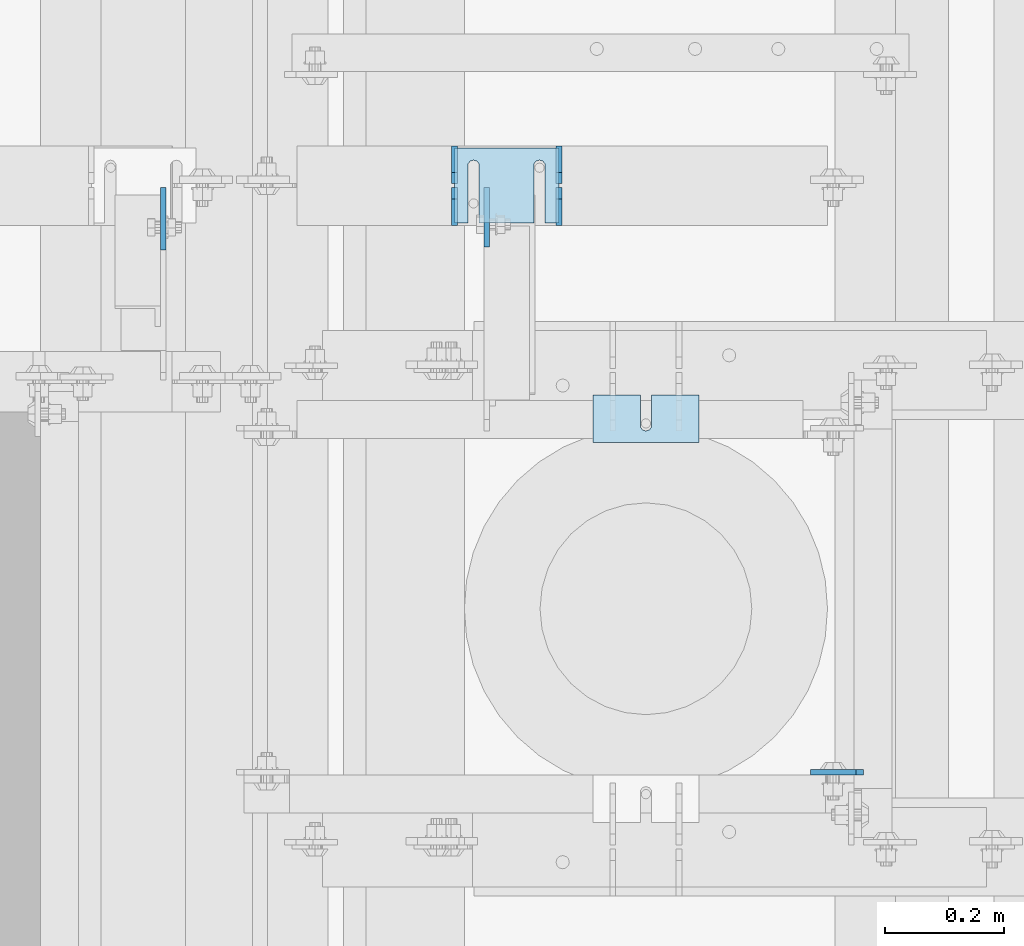
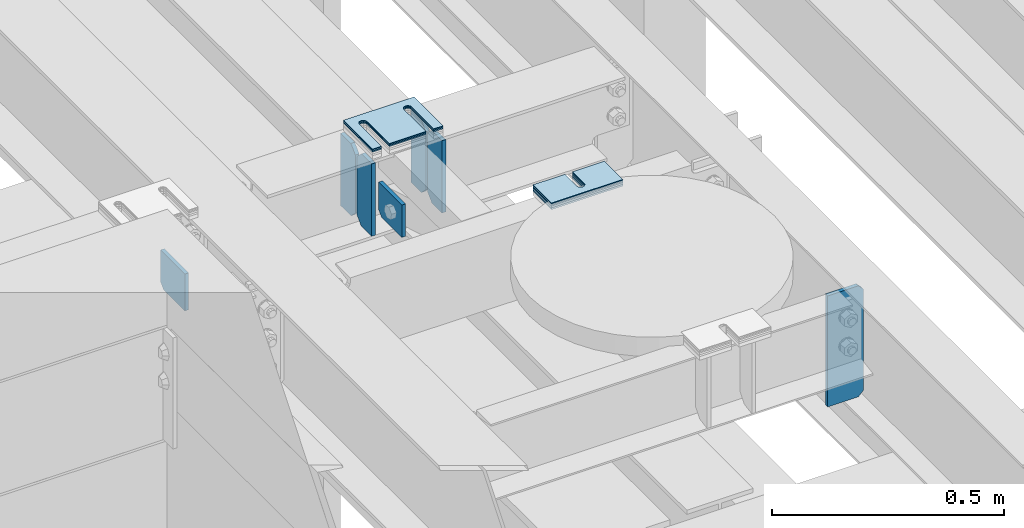
# One storey, part 1610 of 1876: 15 plates, 11 elements without a shape of their own.
"""IFC2X3 building model written with IfcOpenShell, lengths in millimetres."""

import ifcopenshell
import ifcopenshell.guid

model = None  # the IFC model being written
_history = None  # IfcOwnerHistory: only IFC2X3 demands one
_inside = {}  # id of a spatial element -> (the spatial element, [elements in it])
_under = {}  # id of a project, library or spatial element -> (it, [spatial elements below it])
_declared = {}  # id of a project -> (the project, [libraries it declares])
_typed = {}  # id of a type object -> (the type object, [elements of that type])
_made_of = {}  # id of a material, layer set ... -> (it, [elements and type objects made of it])


def new_model(schema):
    """Start an empty IFC model of exactly this schema.

    Asked for "IFC4X3", IfcOpenShell would pick the latest addendum, in which some entities
    have other attributes; the version numbers below select the first issue.
    IFC2X3 requires an IfcOwnerHistory on every rooted entity: one is made here for all.
    """
    global model, _history
    if schema == "IFC4X3":
        model = ifcopenshell.file(schema_version=(4, 3, 0, 0))
    else:
        model = ifcopenshell.file(schema=schema)
    _inside.clear()
    _under.clear()
    _declared.clear()
    _typed.clear()
    _made_of.clear()
    _history = None
    if model.schema == "IFC2X3":
        org = make("IfcOrganization", Name="unknown")
        user = make(
            "IfcPersonAndOrganization",
            ThePerson=make("IfcPerson", FamilyName="unknown"),
            TheOrganization=org,
        )
        app = make(
            "IfcApplication",
            ApplicationDeveloper=org,
            Version="unknown",
            ApplicationFullName="unknown",
            ApplicationIdentifier="unknown",
        )
        _history = make(
            "IfcOwnerHistory",
            OwningUser=user,
            OwningApplication=app,
            ChangeAction="ADDED",
            CreationDate=0,
        )
    return model


def make(cls, **values):
    """One entity of the class cls with the attributes given. An attribute that is None is left unset."""
    return model.create_entity(
        cls, **{name: value for name, value in values.items() if value is not None}
    )


def rooted(cls, **values):
    """An entity with a GlobalId (a new one), such as an element, a storey or a relation."""
    return make(cls, GlobalId=ifcopenshell.guid.new(), OwnerHistory=_history, **values)


def si_unit(unit_type, name, prefix=None):
    """IfcSIUnit, for example si_unit("LENGTHUNIT", "METRE", prefix="MILLI")."""
    return make("IfcSIUnit", UnitType=unit_type, Prefix=prefix, Name=name)


def assignment(units):
    """IfcUnitAssignment: the units of a project."""
    return None if units is None else make("IfcUnitAssignment", Units=units)


def point(xyz):
    """IfcCartesianPoint."""
    return None if xyz is None else make("IfcCartesianPoint", Coordinates=xyz)


def direction(xyz):
    """IfcDirection."""
    return None if xyz is None else make("IfcDirection", DirectionRatios=xyz)


def frame(location, z_axis=None, x_axis=None):
    """IfcAxis2Placement3D, a coordinate frame: its origin and axes. An axis left out is left unset."""
    return make(
        "IfcAxis2Placement3D",
        Location=point(location),
        Axis=direction(z_axis),
        RefDirection=direction(x_axis),
    )


def origin_with_axes():
    """The frame at (0, 0, 0) with the z axis (0, 0, 1) and the x axis (1, 0, 0) written out."""
    return frame((0.0, 0.0, 0.0), z_axis=(0.0, 0.0, 1.0), x_axis=(1.0, 0.0, 0.0))


def place(relative_to, where):
    """IfcLocalPlacement: puts the frame where relative to a parent placement (None: the world)."""
    return make(
        "IfcLocalPlacement", PlacementRelTo=relative_to, RelativePlacement=where
    )


def context(
    kind, dimensions, precision=None, world=None, true_north=None, identifier=None
):
    """IfcGeometricRepresentationContext, for example the 3D "Model" context."""
    return make(
        "IfcGeometricRepresentationContext",
        ContextIdentifier=identifier,
        ContextType=kind,
        CoordinateSpaceDimension=dimensions,
        Precision=precision,
        WorldCoordinateSystem=world,
        TrueNorth=true_north,
    )


def subcontext(parent, identifier, kind, view, scale=None):
    """IfcGeometricRepresentationSubContext, for example "Body" below "Model"."""
    return make(
        "IfcGeometricRepresentationSubContext",
        ContextIdentifier=identifier,
        ContextType=kind,
        ParentContext=parent,
        TargetScale=scale,
        TargetView=view,
    )


def project(units=None, contexts=None):
    """IfcProject with its units and contexts."""
    return rooted(
        "IfcProject",
        Name="project",
        RepresentationContexts=contexts,
        UnitsInContext=assignment(units),
    )


def spatial(cls, under=None, at=None, **own):
    """A site, building, storey or space (cls), placed at a placement, below another one or the project."""
    s = rooted(cls, ObjectPlacement=at, **own)
    if under is not None:
        _under.setdefault(under.id(), (under, []))[1].append(s)
    return s


def faces_of(points, faces, orient=None, outer=None):
    """IfcFace entities. A face is a list of loops; a loop is a list of indices into points, from 0.

    orient and outer hold one flag for each loop. By default every Orientation is true, the
    first loop of a face is its IfcFaceOuterBound and the others are IfcFaceBound.
    """
    made = []
    for i, loops in enumerate(faces):
        bounds = []
        for j, loop in enumerate(loops):
            is_outer = j == 0 if outer is None else outer[i][j]
            bounds.append(
                make(
                    "IfcFaceOuterBound" if is_outer else "IfcFaceBound",
                    Bound=make("IfcPolyLoop", Polygon=[points[k] for k in loop]),
                    Orientation=True if orient is None else orient[i][j],
                )
            )
        made.append(make("IfcFace", Bounds=bounds))
    return made


def faceted_brep(points, faces, orient=None, outer=None, voids=None):
    """IfcFacetedBrep: a solid bounded by flat faces; with voids (closed shells), ...WithVoids."""
    shared = [point(p) for p in points]
    hull = make("IfcClosedShell", CfsFaces=faces_of(shared, faces, orient, outer))
    if voids is None:
        return make("IfcFacetedBrep", Outer=hull)
    return make(
        "IfcFacetedBrepWithVoids",
        Outer=hull,
        Voids=[
            make(cls, CfsFaces=faces_of(shared, fs, o, b)) for cls, fs, o, b in voids
        ],
    )


def shape(context_of_items, identifier, shape_type, items):
    """IfcShapeRepresentation: the items that make up one representation, for example the "Body"."""
    return make(
        "IfcShapeRepresentation",
        ContextOfItems=context_of_items,
        RepresentationIdentifier=identifier,
        RepresentationType=shape_type,
        Items=items,
    )


def material(Name=None, Category=None):
    """IfcMaterial."""
    return make("IfcMaterial", Name=Name, Category=Category)


def made_of(thing, what):
    """Note that an element or type object is made of a material, layer set ...; save() writes the relation."""
    if what is not None:
        _made_of.setdefault(what.id(), (what, []))[1].append(thing)
    return thing


def type_object(cls, material=None, **own):
    """A type object (cls), such as IfcWallType, which elements share."""
    return made_of(rooted(cls, **own), material)


def element(
    cls,
    number,
    at=None,
    inside=None,
    cuts=None,
    type_object=None,
    material=None,
    context=None,
    identifier="Body",
    shape_type=None,
    held_by="IfcProductDefinitionShape",
    body=None,
    shapes=None,
    **own,
):
    """One element of the class cls, such as IfcWall. Its Tag is "e" and its number.

    at: its placement. inside: the storey or other place that contains it. cuts: it is an
    opening in that element (IfcRelVoidsElement). A single representation is given by context,
    identifier, shape_type and body (its items); several are given by shapes. held_by: the class
    of the entity that holds the representations. save() writes the other relations.
    """
    e = rooted(cls, Tag="e%d" % number, ObjectPlacement=at, **own)
    if body is not None:
        shapes = [shape(context, identifier, shape_type, body)]
    if shapes is not None:
        e.Representation = make(held_by, Representations=shapes)
    if inside is not None:
        _inside.setdefault(inside.id(), (inside, []))[1].append(e)
    if cuts is not None:
        rooted(
            "IfcRelVoidsElement", RelatingBuildingElement=cuts, RelatedOpeningElement=e
        )
    if type_object is not None:
        _typed.setdefault(type_object.id(), (type_object, []))[1].append(e)
    return made_of(e, material)


def aggregate(whole, parts):
    """IfcRelAggregates: a whole, such as a stair, and the parts it consists of."""
    return rooted("IfcRelAggregates", RelatingObject=whole, RelatedObjects=parts)


def save(model, path):
    """Write the relations noted so far, then the file.

    IfcRelAggregates (storeys below a building ...), IfcRelContainedInSpatialStructure (elements
    in a storey), IfcRelDefinesByType, IfcRelAssociatesMaterial and IfcRelDeclares: one each for
    every whole, place, type object, material and project.
    """
    for whole, parts in _under.values():
        aggregate(whole, parts)
    for where, things in _inside.values():
        rooted(
            "IfcRelContainedInSpatialStructure",
            RelatedElements=things,
            RelatingStructure=where,
        )
    for kind, things in _typed.values():
        rooted("IfcRelDefinesByType", RelatedObjects=things, RelatingType=kind)
    for what, things in _made_of.values():
        rooted("IfcRelAssociatesMaterial", RelatedObjects=things, RelatingMaterial=what)
    for by, libraries in _declared.values():
        rooted("IfcRelDeclares", RelatingContext=by, RelatedDefinitions=libraries)
    model.write(path)


model = new_model("IFC2X3")

# Units and contexts
model_context = context("Model", 3, precision=1e-05, world=origin_with_axes())
body_context = subcontext(model_context, "Body", "Model", "MODEL_VIEW")
ifc_project = project(units=[si_unit("LENGTHUNIT", "METRE", prefix="MILLI"), si_unit("AREAUNIT", "SQUARE_METRE"), si_unit("VOLUMEUNIT", "CUBIC_METRE"), si_unit("MASSUNIT", "GRAM", prefix="KILO"), si_unit("TIMEUNIT", "SECOND"), si_unit("PLANEANGLEUNIT", "RADIAN"), si_unit("SOLIDANGLEUNIT", "STERADIAN"), si_unit("THERMODYNAMICTEMPERATUREUNIT", "DEGREE_CELSIUS"), si_unit("LUMINOUSINTENSITYUNIT", "LUMEN")], contexts=[model_context])

# Site, building, storey
site_placement = place(None, origin_with_axes())
site = spatial("IfcSite", under=ifc_project, at=site_placement, CompositionType="ELEMENT")
building_placement = place(site_placement, origin_with_axes())
building = spatial("IfcBuilding", under=site, at=building_placement, Name="Undefined", CompositionType="ELEMENT")
storey_placement = place(building_placement, origin_with_axes())
storey = spatial("IfcBuildingStorey", under=building, at=storey_placement, Name="Undefined", CompositionType="ELEMENT", Elevation=0.0)

# Assembly, plates
assembly_1_placement = place(storey_placement, origin_with_axes())
assembly_1 = element("IfcElementAssembly", 1, at=assembly_1_placement, inside=storey, Name="BEAM", AssemblyPlace="NOTDEFINED", PredefinedType="RIGID_FRAME")
ifc_material = material(Name="STEEL/A36")
plate_type_1 = type_object("IfcPlateType", PredefinedType="NOTDEFINED")
plate_1_placement = place(assembly_1_placement, frame((2343.14899226381, 3463.12356567383, 17784.7625), z_axis=(0.0, 0.0, 1.0), x_axis=(0.0, 1.0, 0.0)))
plate_1 = element("IfcPlate", 2, at=plate_1_placement, type_object=plate_type_1, material=ifc_material, Name="PLATE", context=body_context, shape_type="Brep", body=[
    faceted_brep([(0.0, -4.76249999999982, 0.0), (0.0, -4.76249999999982, 190.5), (0.0, 4.76249999999982, 190.5), (0.0, 4.76249999999982, 0.0), (44.4500007629395, -4.76249999999982, 190.5), (44.4500007629395, 4.76249999999982, 190.5), (63.5, -4.76249999999982, 171.450000762939), (63.5, 4.76249999999982, 171.450000762939), (63.5, -4.76249999999982, 19.0499992370605), (63.5, 4.76249999999982, 19.0499992370605), (44.4500007629395, -4.76249999999982, 0.0), (44.4500007629395, 4.76249999999982, 0.0)], [[[0, 1, 2, 3]], [[1, 4, 5, 2]], [[4, 6, 7, 5]], [[6, 8, 9, 7]], [[8, 10, 11, 9]], [[10, 0, 3, 11]], [[5, 7, 9, 11, 3, 2]], [[10, 8, 6, 4, 1, 0]]]),
])
plate_2_placement = place(assembly_1_placement, frame((2343.14899226381, 3532.97356567383, 17784.7625), z_axis=(0.0, 0.0, 1.0), x_axis=(0.0, 1.0, 0.0)))
plate_2 = element("IfcPlate", 3, at=plate_2_placement, type_object=plate_type_1, material=ifc_material, Name="PLATE", context=body_context, shape_type="Brep", body=[
    faceted_brep([(0.0, -4.76249999999982, 19.0499992370605), (0.0, -4.76249999999982, 171.450000762939), (0.0, 4.76249999999982, 171.450000762939), (0.0, 4.76249999999982, 19.0499992370605), (19.0499992370605, -4.76249999999982, 190.5), (19.0499992370605, 4.76249999999982, 190.5), (63.5, -4.76249999999982, 190.5), (63.5, 4.76249999999982, 190.5), (63.5, -4.76249999999982, 0.0), (63.5, 4.76249999999982, 0.0), (19.0499992370605, -4.76249999999982, 0.0), (19.0499992370605, 4.76249999999982, 0.0)], [[[0, 1, 2, 3]], [[1, 4, 5, 2]], [[4, 6, 7, 5]], [[6, 8, 9, 7]], [[8, 10, 11, 9]], [[10, 0, 3, 11]], [[5, 7, 9, 11, 3, 2]], [[10, 8, 6, 4, 1, 0]]]),
])
plate_3_placement = place(assembly_1_placement, frame((2167.75127412195, 3463.12356567383, 17784.7625), z_axis=(0.0, 0.0, 1.0), x_axis=(0.0, 1.0, 0.0)))
plate_3 = element("IfcPlate", 4, at=plate_3_placement, type_object=plate_type_1, material=ifc_material, Name="PLATE", context=body_context, shape_type="Brep", body=[
    faceted_brep([(0.0, -4.76249999999982, 0.0), (0.0, -4.76249999999982, 190.5), (0.0, 4.76249999999982, 190.5), (0.0, 4.76249999999982, 0.0), (44.4500007629395, -4.76249999999982, 190.5), (44.4500007629395, 4.76249999999982, 190.5), (63.5, -4.76249999999982, 171.450000762939), (63.5, 4.76249999999982, 171.450000762939), (63.5, -4.76249999999982, 19.0499992370605), (63.5, 4.76249999999982, 19.0499992370605), (44.4500007629395, -4.76249999999982, 0.0), (44.4500007629395, 4.76249999999982, 0.0)], [[[0, 1, 2, 3]], [[1, 4, 5, 2]], [[4, 6, 7, 5]], [[6, 8, 9, 7]], [[8, 10, 11, 9]], [[10, 0, 3, 11]], [[5, 7, 9, 11, 3, 2]], [[10, 8, 6, 4, 1, 0]]]),
])
plate_4_placement = place(assembly_1_placement, frame((2167.75127412195, 3532.97356567383, 17784.7625), z_axis=(0.0, 0.0, 1.0), x_axis=(0.0, 1.0, 0.0)))
plate_4 = element("IfcPlate", 5, at=plate_4_placement, type_object=plate_type_1, material=ifc_material, Name="PLATE", context=body_context, shape_type="Brep", body=[
    faceted_brep([(0.0, -4.76249999999982, 19.0499992370605), (0.0, -4.76249999999982, 171.450000762939), (0.0, 4.76249999999982, 171.450000762939), (0.0, 4.76249999999982, 19.0499992370605), (19.0499992370605, -4.76249999999982, 190.5), (19.0499992370605, 4.76249999999982, 190.5), (63.5, -4.76249999999982, 190.5), (63.5, 4.76249999999982, 190.5), (63.5, -4.76249999999982, 0.0), (63.5, 4.76249999999982, 0.0), (19.0499992370605, -4.76249999999982, 0.0), (19.0499992370605, 4.76249999999982, 0.0)], [[[0, 1, 2, 3]], [[1, 4, 5, 2]], [[4, 6, 7, 5]], [[6, 8, 9, 7]], [[8, 10, 11, 9]], [[10, 0, 3, 11]], [[5, 7, 9, 11, 3, 2]], [[10, 8, 6, 4, 1, 0]]]),
])

# Assembly, plate
assembly_2_placement = place(storey_placement, origin_with_axes())
assembly_2 = element("IfcElementAssembly", 6, at=assembly_2_placement, inside=storey, Name="BEAM", AssemblyPlace="NOTDEFINED", PredefinedType="RIGID_FRAME")
plate_type_2 = type_object("IfcPlateType", PredefinedType="NOTDEFINED")
plate_5_placement = place(assembly_2_placement, frame((2854.325, 2544.76299991608, 17684.75), z_axis=(0.0, 0.0, 1.0), x_axis=(-1.0, 0.0, 0.0)))
plate_5 = element("IfcPlate", 7, at=plate_5_placement, type_object=plate_type_2, material=ifc_material, Name="PLATE", context=body_context, shape_type="Brep", body=[
    faceted_brep([(3.7040990719106e-08, -4.76249999999982, 12.6999998092651), (0.0, -4.76249999999982, 279.40000629425), (0.0, 4.76249999999982, 279.40000629425), (3.70396264770534e-08, 4.76249999999982, 12.6999998092651), (12.6999998092651, -4.76249999999982, 292.100006103516), (12.6999998092651, 4.76249999999982, 292.100006103516), (88.9000015258789, -4.76249999999982, 292.100006103516), (88.9000015258789, 4.76249999999982, 292.100006103516), (88.9000015258789, -4.76249999999982, 0.0), (88.9000015258789, 4.76249999999982, 0.0), (12.699999809267, -4.76249999999754, 1.09139364212751e-11), (12.6999998092651, 4.76250000000255, 1.09139364212751e-11)], [[[0, 1, 2, 3]], [[1, 4, 5, 2]], [[4, 6, 7, 5]], [[6, 8, 9, 7]], [[8, 10, 11, 9]], [[10, 0, 3, 11]], [[5, 7, 9, 11, 3, 2]], [[10, 8, 6, 4, 1, 0]]]),
])
aggregate(assembly_2, [plate_5])

assembly_3_placement = place(storey_placement, origin_with_axes())
assembly_3 = element("IfcElementAssembly", 8, at=assembly_3_placement, inside=storey, Name="BEAM", AssemblyPlace="NOTDEFINED", PredefinedType="RIGID_FRAME")
plate_type_3 = type_object("IfcPlateType", PredefinedType="NOTDEFINED")
plate_6_placement = place(assembly_3_placement, frame((1679.18756082049, 3421.67282941029, 17881.6674086941), z_axis=(0.0, 1.0, 0.0), x_axis=(0.0, 0.0, -1.0)))
plate_6 = element("IfcPlate", 9, at=plate_6_placement, type_object=plate_type_3, material=ifc_material, Name="PLATE", context=body_context, shape_type="Brep", body=[
    faceted_brep([(0.0, -4.76249999999982, 0.0), (0.0, -4.76249999999209, 104.950782775879), (0.0, 4.76250000000778, 104.950782775878), (0.0, 4.76249999999982, 0.0), (84.2049074172974, -4.76249999999231, 104.950742998794), (84.2049074172974, 4.76250000000778, 104.950742998793), (96.9049072265625, -4.76249999999322, 92.2507371902466), (96.9049072265625, 4.76250000000687, 92.2507371902461), (96.9049072265625, -4.76250000000005, 2.27373675443232e-12), (96.9049072265625, 4.76250000000005, 1.81898940354586e-12)], [[[0, 1, 2, 3]], [[1, 4, 5, 2]], [[4, 6, 7, 5]], [[6, 8, 9, 7]], [[8, 0, 3, 9]], [[5, 7, 9, 3, 2]], [[8, 6, 4, 1, 0]]]),
])
aggregate(assembly_3, [plate_6])

# Plate
plate_type_4 = type_object("IfcPlateType", PredefinedType="NOTDEFINED")
plate_7_placement = place(assembly_1_placement, frame((2222.11237338905, 3526.62351930668, 17784.7625), z_axis=(0.0, -1.0, 0.0), x_axis=(0.0, 0.0, 1.0)))
plate_7 = element("IfcPlate", 10, at=plate_7_placement, type_object=plate_type_4, material=ifc_material, Name="PLATE", context=body_context, shape_type="Brep", body=[
    faceted_brep([(3.7040990719106e-08, -4.76249999999982, 12.6999998092651), (-3.39364123647101e-06, -4.76250000000164, 99.8198623657227), (-3.39364123647101e-06, 4.76249999999845, 99.8198623657231), (3.70396264770534e-08, 4.76249999999982, 12.6999998092651), (85.3342742920504, -4.76250000000118, 99.8198623657154), (85.3342742920504, 4.76249999999891, 99.8198623657154), (85.3342742919958, -4.76250000000027, -6.82121026329696e-11), (85.3342742919958, 4.76249999999936, -6.86668499838561e-11), (12.699999809267, -4.76249999999754, 1.09139364212751e-11), (12.6999998092651, 4.76250000000255, 1.09139364212751e-11)], [[[0, 1, 2, 3]], [[1, 4, 5, 2]], [[4, 6, 7, 5]], [[6, 8, 9, 7]], [[8, 0, 3, 9]], [[5, 7, 9, 3, 2]], [[8, 6, 4, 1, 0]]]),
])

aggregate(assembly_1, [plate_1, plate_2, plate_3, plate_4, plate_7])

# Assembly, plate
assembly_4_placement = place(storey_placement, origin_with_axes())
assembly_4 = element("IfcElementAssembly", 11, at=assembly_4_placement, inside=storey, Name="SHIM PLATE", AssemblyPlace="NOTDEFINED", PredefinedType="RIGID_FRAME")
plate_type_5 = type_object("IfcPlateType", PredefinedType="NOTDEFINED")
plate_8_placement = place(assembly_4_placement, frame((2578.11073971347, 3098.8, 18009.3925), z_axis=(0.0, 1.0, 0.0), x_axis=(-1.0, 0.0, 0.0)))
plate_8 = element("IfcPlate", 12, at=plate_8_placement, type_object=plate_type_5, material=ifc_material, Name="SHIM PLATE", context=body_context, shape_type="Brep", body=[
    faceted_brep([(79.383495528351, -0.793499999999767, 79.3780288696357), (79.3844214322648, -0.793499999999767, 31.7467767062135), (79.3844214322648, 0.793499999999767, 31.7467767062135), (79.383495528351, 0.793499999999767, 79.3780288696357), (79.5371482496867, -0.793499999999767, 25.7122407615266), (79.5371482496867, 0.793499999999767, 25.7122407615266), (83.1590254736952, -0.793499999999767, 20.8830633033372), (83.1590254736952, 0.793499999999767, 20.8830633033372), (88.909413614851, -0.793499999999767, 19.0467665477618), (88.909413614851, 0.793499999999767, 19.0467665477618), (94.6598039068872, -0.793499999999767, 20.8830565678104), (94.6598039068872, 0.793499999999767, 20.8830565678104), (98.2816867873894, -0.793499999999767, 25.7122297836318), (98.2816867873894, 0.793499999999767, 25.7122297836318), (98.4344206731635, -0.793499999999767, 31.7467655494229), (98.4344206731635, 0.793499999999767, 31.7467655494229), (98.433494769024, -0.793499999999767, 79.3780288696371), (98.433494769024, 0.793499999999767, 79.3780288696371), (9.09494701772928e-13, -0.793499999999767, 0.0), (2.0060193946847e-05, -0.793499999999767, 79.3780288696289), (2.0060193946847e-05, 0.793499999999767, 79.3780288696289), (9.09494701772928e-13, 0.793499999999767, 0.0), (177.799530029297, -0.793499999999767, -1.77351466845721e-11), (177.799530029297, 0.793499999999767, -1.77351466845721e-11), (177.799545288079, -0.793499999999767, 79.3780288696435), (177.799545288079, 0.793499999999767, 79.3780288696435)], [[[0, 1, 2, 3]], [[4, 5, 2, 1]], [[6, 7, 5, 4]], [[8, 9, 7, 6]], [[10, 11, 9, 8]], [[12, 13, 11, 10]], [[14, 15, 13, 12]], [[16, 17, 15, 14]], [[18, 19, 20, 21]], [[22, 18, 21, 23]], [[24, 22, 23, 25]], [[12, 10, 8, 6, 4, 1, 0, 19, 18, 22, 24, 16, 14]], [[20, 19, 0, 3]], [[25, 23, 21, 20, 3, 2, 5, 7, 9, 11, 13, 15, 17]], [[24, 25, 17, 16]]]),
])
aggregate(assembly_4, [plate_8])

assembly_5_placement = place(storey_placement, origin_with_axes())
assembly_5 = element("IfcElementAssembly", 13, at=assembly_5_placement, inside=storey, Name="SHIM PLATE", AssemblyPlace="NOTDEFINED", PredefinedType="RIGID_FRAME")
plate_type_6 = type_object("IfcPlateType", PredefinedType="NOTDEFINED")
plate_9_placement = place(assembly_5_placement, frame((2578.11073971347, 3098.8, 18007.0115), z_axis=(0.0, 1.0, 0.0), x_axis=(-1.0, 0.0, 0.0)))
plate_9 = element("IfcPlate", 14, at=plate_9_placement, type_object=plate_type_6, material=ifc_material, Name="SHIM PLATE", context=body_context, shape_type="Brep", body=[
    faceted_brep([(79.383495528351, -1.58750000000146, 79.3780288696357), (79.3844214322648, -1.58750000000146, 31.7467767062135), (79.3844214322648, 1.58750000000146, 31.7467767062135), (79.383495528351, 1.58750000000146, 79.3780288696357), (79.5371482496867, -1.58750000000146, 25.7122407615266), (79.5371482496867, 1.58750000000146, 25.7122407615266), (83.1590254736952, -1.58750000000146, 20.8830633033372), (83.1590254736952, 1.58750000000146, 20.8830633033372), (88.909413614851, -1.58750000000146, 19.0467665477618), (88.909413614851, 1.58750000000146, 19.0467665477618), (94.6598039068872, -1.58750000000146, 20.8830565678104), (94.6598039068872, 1.58750000000146, 20.8830565678104), (98.2816867873894, -1.58750000000146, 25.7122297836318), (98.2816867873894, 1.58750000000146, 25.7122297836318), (98.4344206731635, -1.58750000000146, 31.7467655494229), (98.4344206731635, 1.58750000000146, 31.7467655494229), (98.433494769024, -1.58750000000146, 79.3780288696371), (98.433494769024, 1.58750000000146, 79.3780288696371), (9.09494701772928e-13, -1.58750000000146, 4.54747350886464e-13), (2.0060193946847e-05, -1.58750000000146, 79.3780288696289), (2.0060193946847e-05, 1.58750000000146, 79.3780288696289), (9.09494701772928e-13, 1.58750000000146, 4.54747350886464e-13), (177.799530029297, -1.58750000000146, -1.77351466845721e-11), (177.799530029297, 1.58750000000146, -1.77351466845721e-11), (177.799545288079, -1.58750000000146, 79.3780288696435), (177.799545288079, 1.58750000000146, 79.3780288696435)], [[[0, 1, 2, 3]], [[4, 5, 2, 1]], [[6, 7, 5, 4]], [[8, 9, 7, 6]], [[10, 11, 9, 8]], [[12, 13, 11, 10]], [[14, 15, 13, 12]], [[16, 17, 15, 14]], [[18, 19, 20, 21]], [[22, 18, 21, 23]], [[24, 22, 23, 25]], [[12, 10, 8, 6, 4, 1, 0, 19, 18, 22, 24, 16, 14]], [[20, 19, 0, 3]], [[25, 23, 21, 20, 3, 2, 5, 7, 9, 11, 13, 15, 17]], [[24, 25, 17, 16]]]),
])
aggregate(assembly_5, [plate_9])

assembly_6_placement = place(storey_placement, origin_with_axes())
assembly_6 = element("IfcElementAssembly", 15, at=assembly_6_placement, inside=storey, Name="SHIM PLATE", AssemblyPlace="NOTDEFINED", PredefinedType="RIGID_FRAME")
plate_10_placement = place(assembly_6_placement, frame((2578.11073971347, 3098.8, 18003.8365), z_axis=(0.0, 1.0, 0.0), x_axis=(-1.0, 0.0, 0.0)))
plate_10 = element("IfcPlate", 16, at=plate_10_placement, type_object=plate_type_6, material=ifc_material, Name="SHIM PLATE", context=body_context, shape_type="Brep", body=[
    faceted_brep([(79.383495528351, -1.58750000000146, 79.3780288696357), (79.3844214322648, -1.58750000000146, 31.7467767062135), (79.3844214322648, 1.58750000000146, 31.7467767062135), (79.383495528351, 1.58750000000146, 79.3780288696357), (79.5371482496867, -1.58750000000146, 25.7122407615266), (79.5371482496867, 1.58750000000146, 25.7122407615266), (83.1590254736952, -1.58750000000146, 20.8830633033372), (83.1590254736952, 1.58750000000146, 20.8830633033372), (88.909413614851, -1.58750000000146, 19.0467665477618), (88.909413614851, 1.58750000000146, 19.0467665477618), (94.6598039068872, -1.58750000000146, 20.8830565678104), (94.6598039068872, 1.58750000000146, 20.8830565678104), (98.2816867873894, -1.58750000000146, 25.7122297836318), (98.2816867873894, 1.58750000000146, 25.7122297836318), (98.4344206731635, -1.58750000000146, 31.7467655494229), (98.4344206731635, 1.58750000000146, 31.7467655494229), (98.433494769024, -1.58750000000146, 79.3780288696371), (98.433494769024, 1.58750000000146, 79.3780288696371), (9.09494701772928e-13, -1.58750000000146, 4.54747350886464e-13), (2.0060193946847e-05, -1.58750000000146, 79.3780288696289), (2.0060193946847e-05, 1.58750000000146, 79.3780288696289), (9.09494701772928e-13, 1.58750000000146, 4.54747350886464e-13), (177.799530029297, -1.58750000000146, -1.77351466845721e-11), (177.799530029297, 1.58750000000146, -1.77351466845721e-11), (177.799545288079, -1.58750000000146, 79.3780288696435), (177.799545288079, 1.58750000000146, 79.3780288696435)], [[[0, 1, 2, 3]], [[4, 5, 2, 1]], [[6, 7, 5, 4]], [[8, 9, 7, 6]], [[10, 11, 9, 8]], [[12, 13, 11, 10]], [[14, 15, 13, 12]], [[16, 17, 15, 14]], [[18, 19, 20, 21]], [[22, 18, 21, 23]], [[24, 22, 23, 25]], [[12, 10, 8, 6, 4, 1, 0, 19, 18, 22, 24, 16, 14]], [[20, 19, 0, 3]], [[25, 23, 21, 20, 3, 2, 5, 7, 9, 11, 13, 15, 17]], [[24, 25, 17, 16]]]),
])
aggregate(assembly_6, [plate_10])

assembly_7_placement = place(storey_placement, origin_with_axes())
assembly_7 = element("IfcElementAssembly", 17, at=assembly_7_placement, inside=storey, Name="SHIM PLATE", AssemblyPlace="NOTDEFINED", PredefinedType="RIGID_FRAME")
plate_type_7 = type_object("IfcPlateType", PredefinedType="NOTDEFINED")
plate_11_placement = place(assembly_7_placement, frame((2578.11073971348, 3098.8, 17999.868), z_axis=(0.0, 1.0, 0.0), x_axis=(-1.0, 0.0, 0.0)))
plate_11 = element("IfcPlate", 18, at=plate_11_placement, type_object=plate_type_7, material=ifc_material, Name="SHIM PLATE", context=body_context, shape_type="Brep", body=[
    faceted_brep([(79.383495528351, -2.38100000000122, 79.3780288696357), (79.3844214322648, -2.38100000000122, 31.7467767062135), (79.3844214322648, 2.38100000000122, 31.7467767062135), (79.383495528351, 2.38100000000122, 79.3780288696357), (79.5371482496867, -2.38100000000122, 25.7122407615266), (79.5371482496867, 2.38100000000122, 25.7122407615266), (83.1590254736952, -2.38100000000122, 20.8830633033372), (83.1590254736952, 2.38100000000122, 20.8830633033372), (88.909413614851, -2.38100000000122, 19.0467665477618), (88.909413614851, 2.38100000000122, 19.0467665477618), (94.6598039068872, -2.38100000000122, 20.8830565678104), (94.6598039068872, 2.38100000000122, 20.8830565678104), (98.2816867873894, -2.38100000000122, 25.7122297836318), (98.2816867873894, 2.38100000000122, 25.7122297836318), (98.4344206731635, -2.38100000000122, 31.7467655494229), (98.4344206731635, 2.38100000000122, 31.7467655494229), (98.433494769024, -2.38100000000122, 79.3780288696371), (98.433494769024, 2.38100000000122, 79.3780288696371), (0.0, -2.38100000000122, 4.54747350886464e-13), (2.0060193946847e-05, -2.38100000000122, 79.3780288696289), (2.0060193946847e-05, 2.38100000000122, 79.3780288696289), (0.0, 2.38100000000122, 4.54747350886464e-13), (177.799530029297, -2.38100000000122, -1.77351466845721e-11), (177.799530029297, 2.38100000000122, -1.77351466845721e-11), (177.799545288079, -2.38100000000122, 79.3780288696435), (177.799545288079, 2.38100000000122, 79.3780288696435)], [[[0, 1, 2, 3]], [[4, 5, 2, 1]], [[6, 7, 5, 4]], [[8, 9, 7, 6]], [[10, 11, 9, 8]], [[12, 13, 11, 10]], [[14, 15, 13, 12]], [[16, 17, 15, 14]], [[18, 19, 20, 21]], [[22, 18, 21, 23]], [[24, 22, 23, 25]], [[12, 10, 8, 6, 4, 1, 0, 19, 18, 22, 24, 16, 14]], [[20, 19, 0, 3]], [[25, 23, 21, 20, 3, 2, 5, 7, 9, 11, 13, 15, 17]], [[24, 25, 17, 16]]]),
])
aggregate(assembly_7, [plate_11])

assembly_8_placement = place(storey_placement, origin_with_axes())
assembly_8 = element("IfcElementAssembly", 19, at=assembly_8_placement, inside=storey, Name="SHIM PLATE", AssemblyPlace="NOTDEFINED", PredefinedType="RIGID_FRAME")
plate_12_placement = place(assembly_8_placement, frame((2578.11073971347, 3098.8, 17995.106), z_axis=(0.0, 1.0, 0.0), x_axis=(-1.0, 0.0, 0.0)))
plate_12 = element("IfcPlate", 20, at=plate_12_placement, type_object=plate_type_7, material=ifc_material, Name="SHIM PLATE", context=body_context, shape_type="Brep", body=[
    faceted_brep([(79.383495528351, -2.38100000000122, 79.3780288696357), (79.3844214322648, -2.38100000000122, 31.7467767062135), (79.3844214322648, 2.38100000000122, 31.7467767062135), (79.383495528351, 2.38100000000122, 79.3780288696357), (79.5371482496867, -2.38100000000122, 25.7122407615266), (79.5371482496867, 2.38100000000122, 25.7122407615266), (83.1590254736952, -2.38100000000122, 20.8830633033372), (83.1590254736952, 2.38100000000122, 20.8830633033372), (88.909413614851, -2.38100000000122, 19.0467665477618), (88.909413614851, 2.38100000000122, 19.0467665477618), (94.6598039068872, -2.38100000000122, 20.8830565678104), (94.6598039068872, 2.38100000000122, 20.8830565678104), (98.2816867873894, -2.38100000000122, 25.7122297836318), (98.2816867873894, 2.38100000000122, 25.7122297836318), (98.4344206731635, -2.38100000000122, 31.7467655494229), (98.4344206731635, 2.38100000000122, 31.7467655494229), (98.433494769024, -2.38100000000122, 79.3780288696371), (98.433494769024, 2.38100000000122, 79.3780288696371), (0.0, -2.38100000000122, 4.54747350886464e-13), (2.0060193946847e-05, -2.38100000000122, 79.3780288696289), (2.0060193946847e-05, 2.38100000000122, 79.3780288696289), (0.0, 2.38100000000122, 4.54747350886464e-13), (177.799530029297, -2.38100000000122, -1.77351466845721e-11), (177.799530029297, 2.38100000000122, -1.77351466845721e-11), (177.799545288079, -2.38100000000122, 79.3780288696435), (177.799545288079, 2.38100000000122, 79.3780288696435)], [[[0, 1, 2, 3]], [[4, 5, 2, 1]], [[6, 7, 5, 4]], [[8, 9, 7, 6]], [[10, 11, 9, 8]], [[12, 13, 11, 10]], [[14, 15, 13, 12]], [[16, 17, 15, 14]], [[18, 19, 20, 21]], [[22, 18, 21, 23]], [[24, 22, 23, 25]], [[12, 10, 8, 6, 4, 1, 0, 19, 18, 22, 24, 16, 14]], [[20, 19, 0, 3]], [[25, 23, 21, 20, 3, 2, 5, 7, 9, 11, 13, 15, 17]], [[24, 25, 17, 16]]]),
])
aggregate(assembly_8, [plate_12])

assembly_9_placement = place(storey_placement, origin_with_axes())
assembly_9 = element("IfcElementAssembly", 21, at=assembly_9_placement, inside=storey, Name="SHIM PLATE", AssemblyPlace="NOTDEFINED", PredefinedType="RIGID_FRAME")
plate_type_8 = type_object("IfcPlateType", PredefinedType="NOTDEFINED")
plate_13_placement = place(assembly_9_placement, frame((2343.14900265255, 3592.49779911282, 18009.3925), z_axis=(0.0, -1.0, 0.0), x_axis=(-1.0, 0.0, 0.0)))
plate_13 = element("IfcPlate", 22, at=plate_13_placement, type_object=plate_type_8, material=ifc_material, Name="SHIM PLATE", context=body_context, shape_type="Brep", body=[
    faceted_brep([(133.797984932592, -0.793499999999767, 125.39846801759), (133.799788185712, -0.793499999999767, 32.6385373098888), (133.799788185712, 0.793499999999767, 32.6385373098888), (133.797984932592, 0.793499999999767, 125.39846801759), (133.95251601168, -0.793499999999767, 26.6039999741197), (133.95251601168, 0.793499999999767, 26.6039999741197), (137.574395327988, -0.793499999999767, 21.7748223149583), (137.574395327988, 0.793499999999767, 21.7748223149583), (143.324785467194, -0.793499999999767, 19.9385271609622), (143.324785467194, 0.793499999999767, 19.9385271609622), (149.075176282759, -0.793499999999767, 21.7748201969102), (149.075176282759, 0.793499999999767, 21.7748201969102), (152.697057377795, -0.793499999999767, 26.6039965220207), (152.697057377795, 0.793499999999767, 26.6039965220207), (152.84978742646, -0.793499999999767, 32.6385338015343), (152.84978742646, 0.793499999999767, 32.6385338015343), (152.847984173361, -0.793499999999767, 125.398468017593), (152.847984173361, 0.793499999999767, 125.398468017593), (42.2236708188493, -0.793499999999767, 125.398468017582), (42.2236708188493, 0.793499999999767, 125.398468017582), (42.2254740719682, 0.793499999999767, 32.6385328059155), (42.2254740719682, -0.793499999999767, 32.6385328059155), (42.0727440233031, 0.793499999999767, 26.6039955264014), (42.0727440233031, -0.793499999999767, 26.6039955264014), (38.4508629282668, 0.793499999999767, 21.7748192012914), (38.4508629282668, -0.793499999999767, 21.7748192012914), (32.7004721127014, 0.793499999999767, 19.9385261653433), (32.7004721127014, -0.793499999999767, 19.9385261653433), (26.9500819734958, 0.793499999999767, 21.7748213193395), (26.9500819734958, -0.793499999999767, 21.7748213193395), (23.3282026571874, 0.793499999999767, 26.6039989785008), (23.3282026571874, -0.793499999999767, 26.6039989785008), (23.1754748312196, 0.793499999999767, 32.6385363142699), (23.1754748312196, -0.793499999999767, 32.6385363142699), (23.1736715780803, -0.793499999999767, 125.39846801758), (23.1736715780803, 0.793499999999767, 125.39846801758), (1.96488858819066e-05, 0.793499999999767, 125.398468017578), (1.96488858819066e-05, -0.793499999999767, 125.398468017578), (9.09494701772928e-13, -0.793499999999767, 0.0), (9.09494701772928e-13, 0.793499999999767, 0.0), (175.397720336914, -0.793499999999767, 7.27595761418343e-12), (175.397720336914, 0.793499999999767, 7.27595761418343e-12), (175.397735595691, -0.793499999999767, 125.398468017594), (175.397735595691, 0.793499999999767, 125.398468017594)], [[[0, 1, 2, 3]], [[4, 5, 2, 1]], [[6, 7, 5, 4]], [[8, 9, 7, 6]], [[10, 11, 9, 8]], [[12, 13, 11, 10]], [[14, 15, 13, 12]], [[16, 17, 15, 14]], [[18, 19, 20, 21]], [[21, 20, 22, 23]], [[23, 22, 24, 25]], [[25, 24, 26, 27]], [[27, 26, 28, 29]], [[29, 28, 30, 31]], [[31, 30, 32, 33]], [[34, 33, 32, 35]], [[36, 37, 34, 35]], [[38, 37, 36, 39]], [[40, 38, 39, 41]], [[42, 40, 41, 43]], [[12, 10, 8, 6, 4, 1, 0, 18, 21, 23, 25, 27, 29, 31, 33, 34, 37, 38, 40, 42, 16, 14]], [[19, 18, 0, 3]], [[43, 41, 39, 36, 35, 32, 30, 28, 26, 24, 22, 20, 19, 3, 2, 5, 7, 9, 11, 13, 15, 17]], [[42, 43, 17, 16]]]),
])
aggregate(assembly_9, [plate_13])

assembly_10_placement = place(storey_placement, origin_with_axes())
assembly_10 = element("IfcElementAssembly", 23, at=assembly_10_placement, inside=storey, Name="SHIM PLATE", AssemblyPlace="NOTDEFINED", PredefinedType="RIGID_FRAME")
plate_type_9 = type_object("IfcPlateType", PredefinedType="NOTDEFINED")
plate_14_placement = place(assembly_10_placement, frame((2343.14900265255, 3592.4977991129, 18007.0115), z_axis=(0.0, -1.0, 0.0), x_axis=(-1.0, 0.0, 0.0)))
plate_14 = element("IfcPlate", 24, at=plate_14_placement, type_object=plate_type_9, material=ifc_material, Name="SHIM PLATE", context=body_context, shape_type="Brep", body=[
    faceted_brep([(133.797984932592, -1.58750000000146, 125.39846801759), (133.799788185712, -1.58750000000146, 32.6385373098888), (133.799788185712, 1.58750000000146, 32.6385373098888), (133.797984932592, 1.58750000000146, 125.39846801759), (133.95251601168, -1.58750000000146, 26.6039999741197), (133.95251601168, 1.58750000000146, 26.6039999741197), (137.574395327988, -1.58750000000146, 21.7748223149583), (137.574395327988, 1.58750000000146, 21.7748223149583), (143.324785467194, -1.58750000000146, 19.9385271609622), (143.324785467194, 1.58750000000146, 19.9385271609622), (149.075176282759, -1.58750000000146, 21.7748201969102), (149.075176282759, 1.58750000000146, 21.7748201969102), (152.697057377795, -1.58750000000146, 26.6039965220207), (152.697057377795, 1.58750000000146, 26.6039965220207), (152.84978742646, -1.58750000000146, 32.6385338015343), (152.84978742646, 1.58750000000146, 32.6385338015343), (152.847984173361, -1.58750000000146, 125.398468017593), (152.847984173361, 1.58750000000146, 125.398468017593), (42.2236708188493, -1.58750000000146, 125.398468017582), (42.2236708188493, 1.58750000000146, 125.398468017582), (42.2254740719682, 1.58750000000146, 32.6385328059155), (42.2254740719682, -1.58750000000146, 32.6385328059155), (42.0727440233031, 1.58750000000146, 26.6039955264014), (42.0727440233031, -1.58750000000146, 26.6039955264014), (38.4508629282668, 1.58750000000146, 21.7748192012914), (38.4508629282668, -1.58750000000146, 21.7748192012914), (32.7004721127014, 1.58750000000146, 19.9385261653433), (32.7004721127014, -1.58750000000146, 19.9385261653433), (26.9500819734958, 1.58750000000146, 21.7748213193395), (26.9500819734958, -1.58750000000146, 21.7748213193395), (23.3282026571874, 1.58750000000146, 26.6039989785008), (23.3282026571874, -1.58750000000146, 26.6039989785008), (23.1754748312196, 1.58750000000146, 32.6385363142699), (23.1754748312196, -1.58750000000146, 32.6385363142699), (23.1736715780803, -1.58750000000146, 125.39846801758), (23.1736715780803, 1.58750000000146, 125.39846801758), (1.96491696442536e-05, 1.58750000000146, 125.398468017578), (1.96491696442536e-05, -1.58750000000146, 125.398468017578), (9.09494701772928e-13, -1.58750000000146, 4.54747350886464e-13), (9.09494701772928e-13, 1.58750000000146, 4.54747350886464e-13), (175.397720336914, -1.58750000000146, 7.27595761418343e-12), (175.397720336914, 1.58750000000146, 7.27595761418343e-12), (175.397735595691, -1.58750000000146, 125.398468017594), (175.397735595691, 1.58750000000146, 125.398468017594)], [[[0, 1, 2, 3]], [[4, 5, 2, 1]], [[6, 7, 5, 4]], [[8, 9, 7, 6]], [[10, 11, 9, 8]], [[12, 13, 11, 10]], [[14, 15, 13, 12]], [[16, 17, 15, 14]], [[18, 19, 20, 21]], [[21, 20, 22, 23]], [[23, 22, 24, 25]], [[25, 24, 26, 27]], [[27, 26, 28, 29]], [[29, 28, 30, 31]], [[31, 30, 32, 33]], [[34, 33, 32, 35]], [[36, 37, 34, 35]], [[38, 37, 36, 39]], [[40, 38, 39, 41]], [[42, 40, 41, 43]], [[12, 10, 8, 6, 4, 1, 0, 18, 21, 23, 25, 27, 29, 31, 33, 34, 37, 38, 40, 42, 16, 14]], [[19, 18, 0, 3]], [[43, 41, 39, 36, 35, 32, 30, 28, 26, 24, 22, 20, 19, 3, 2, 5, 7, 9, 11, 13, 15, 17]], [[42, 43, 17, 16]]]),
])
aggregate(assembly_10, [plate_14])

assembly_11_placement = place(storey_placement, origin_with_axes())
assembly_11 = element("IfcElementAssembly", 25, at=assembly_11_placement, inside=storey, Name="SHIM PLATE", AssemblyPlace="NOTDEFINED", PredefinedType="RIGID_FRAME")
plate_15_placement = place(assembly_11_placement, frame((2343.14900265254, 3592.49779911298, 18003.8365), z_axis=(0.0, -1.0, 0.0), x_axis=(-1.0, 0.0, 0.0)))
plate_15 = element("IfcPlate", 26, at=plate_15_placement, type_object=plate_type_9, material=ifc_material, Name="SHIM PLATE", context=body_context, shape_type="Brep", body=[
    faceted_brep([(133.797984932592, -1.58750000000146, 125.39846801759), (133.799788185712, -1.58750000000146, 32.6385373098888), (133.799788185712, 1.58750000000146, 32.6385373098888), (133.797984932592, 1.58750000000146, 125.39846801759), (133.95251601168, -1.58750000000146, 26.6039999741197), (133.95251601168, 1.58750000000146, 26.6039999741197), (137.574395327988, -1.58750000000146, 21.7748223149583), (137.574395327988, 1.58750000000146, 21.7748223149583), (143.324785467194, -1.58750000000146, 19.9385271609622), (143.324785467194, 1.58750000000146, 19.9385271609622), (149.075176282759, -1.58750000000146, 21.7748201969102), (149.075176282759, 1.58750000000146, 21.7748201969102), (152.697057377795, -1.58750000000146, 26.6039965220207), (152.697057377795, 1.58750000000146, 26.6039965220207), (152.84978742646, -1.58750000000146, 32.6385338015343), (152.84978742646, 1.58750000000146, 32.6385338015343), (152.847984173361, -1.58750000000146, 125.398468017593), (152.847984173361, 1.58750000000146, 125.398468017593), (42.2236708188493, -1.58750000000146, 125.398468017582), (42.2236708188493, 1.58750000000146, 125.398468017582), (42.2254740719682, 1.58750000000146, 32.6385328059155), (42.2254740719682, -1.58750000000146, 32.6385328059155), (42.0727440233031, 1.58750000000146, 26.6039955264014), (42.0727440233031, -1.58750000000146, 26.6039955264014), (38.4508629282668, 1.58750000000146, 21.7748192012914), (38.4508629282668, -1.58750000000146, 21.7748192012914), (32.7004721127014, 1.58750000000146, 19.9385261653433), (32.7004721127014, -1.58750000000146, 19.9385261653433), (26.9500819734958, 1.58750000000146, 21.7748213193395), (26.9500819734958, -1.58750000000146, 21.7748213193395), (23.3282026571874, 1.58750000000146, 26.6039989785008), (23.3282026571874, -1.58750000000146, 26.6039989785008), (23.1754748312196, 1.58750000000146, 32.6385363142699), (23.1754748312196, -1.58750000000146, 32.6385363142699), (23.1736715780803, -1.58750000000146, 125.39846801758), (23.1736715780803, 1.58750000000146, 125.39846801758), (1.96491696442536e-05, 1.58750000000146, 125.398468017578), (1.96491696442536e-05, -1.58750000000146, 125.398468017578), (9.09494701772928e-13, -1.58750000000146, 4.54747350886464e-13), (9.09494701772928e-13, 1.58750000000146, 4.54747350886464e-13), (175.397720336914, -1.58750000000146, 7.27595761418343e-12), (175.397720336914, 1.58750000000146, 7.27595761418343e-12), (175.397735595691, -1.58750000000146, 125.398468017594), (175.397735595691, 1.58750000000146, 125.398468017594)], [[[0, 1, 2, 3]], [[4, 5, 2, 1]], [[6, 7, 5, 4]], [[8, 9, 7, 6]], [[10, 11, 9, 8]], [[12, 13, 11, 10]], [[14, 15, 13, 12]], [[16, 17, 15, 14]], [[18, 19, 20, 21]], [[21, 20, 22, 23]], [[23, 22, 24, 25]], [[25, 24, 26, 27]], [[27, 26, 28, 29]], [[29, 28, 30, 31]], [[31, 30, 32, 33]], [[34, 33, 32, 35]], [[36, 37, 34, 35]], [[38, 37, 36, 39]], [[40, 38, 39, 41]], [[42, 40, 41, 43]], [[12, 10, 8, 6, 4, 1, 0, 18, 21, 23, 25, 27, 29, 31, 33, 34, 37, 38, 40, 42, 16, 14]], [[19, 18, 0, 3]], [[43, 41, 39, 36, 35, 32, 30, 28, 26, 24, 22, 20, 19, 3, 2, 5, 7, 9, 11, 13, 15, 17]], [[42, 43, 17, 16]]]),
])
aggregate(assembly_11, [plate_15])

save(model, "model.ifc")
